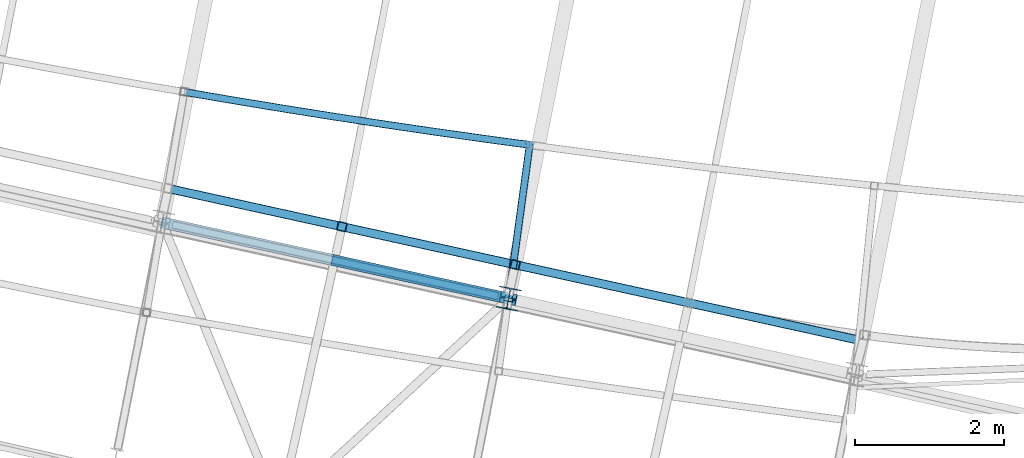
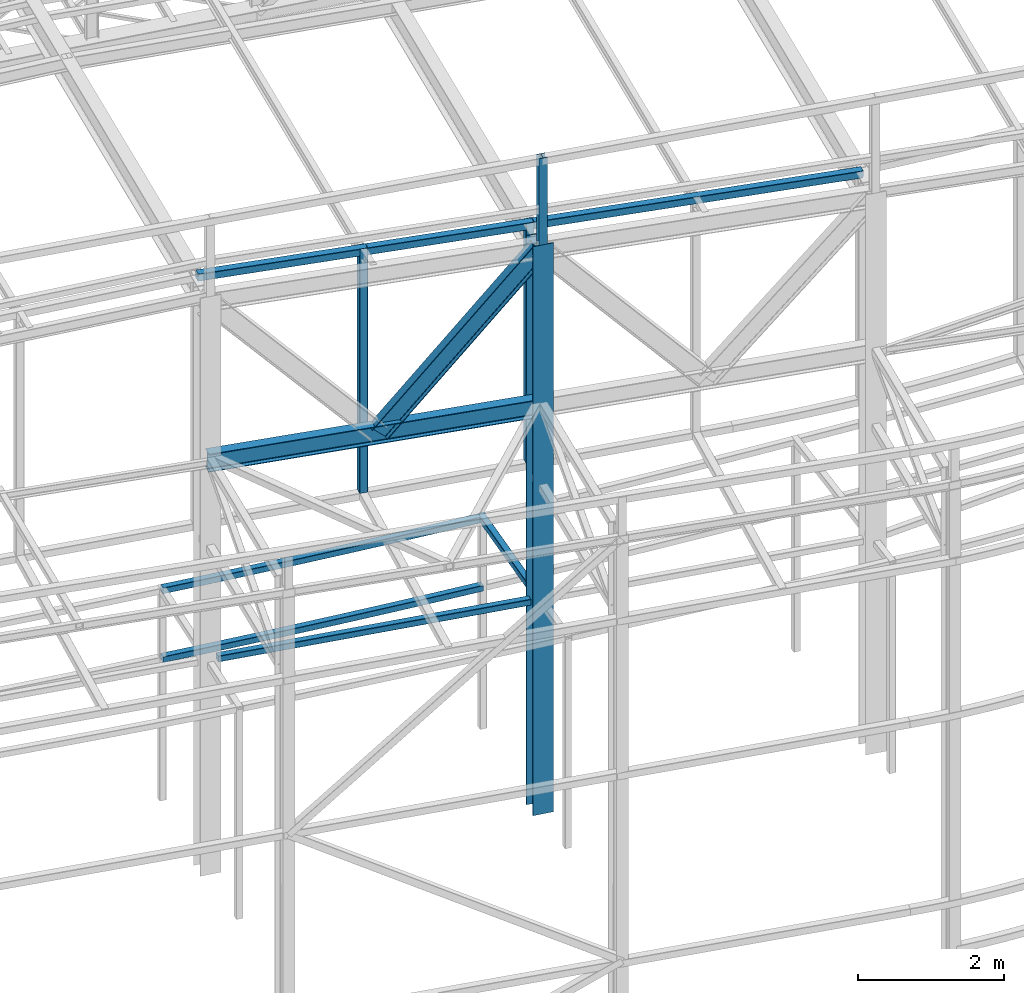
# One storey, part 48 of 215: 10 beams, 1 member, 11 elements without a shape of their own.
"""IFC2X3 building model written with IfcOpenShell, lengths in millimetres."""

from ifc_helpers import new_model, entity, si_unit, frame, origin_with_axes, origin_2d_with_axis, place, context, subcontext, project, spatial, hollow_rectangle, i_section, extrude, clip, halfspace, material, type_object, element, aggregate, save


model = new_model("IFC2X3")

# Units and contexts
model_context = context("Model", 3, precision=1e-05, world=origin_with_axes())
body_context = subcontext(model_context, "Body", "Model", "MODEL_VIEW")
ifc_project = project(units=[si_unit("LENGTHUNIT", "METRE", prefix="MILLI"), si_unit("AREAUNIT", "SQUARE_METRE"), si_unit("VOLUMEUNIT", "CUBIC_METRE"), si_unit("MASSUNIT", "GRAM", prefix="KILO"), si_unit("TIMEUNIT", "SECOND"), si_unit("PLANEANGLEUNIT", "RADIAN"), si_unit("SOLIDANGLEUNIT", "STERADIAN"), si_unit("THERMODYNAMICTEMPERATUREUNIT", "DEGREE_CELSIUS"), si_unit("LUMINOUSINTENSITYUNIT", "LUMEN")], contexts=[model_context])

# Site, building, storey
site_placement = place(None, origin_with_axes())
site = spatial("IfcSite", under=ifc_project, at=site_placement, CompositionType="ELEMENT")
building_placement = place(site_placement, origin_with_axes())
building = spatial("IfcBuilding", under=site, at=building_placement, Name="Undefined", CompositionType="ELEMENT")
storey_placement = place(building_placement, origin_with_axes())
storey = spatial("IfcBuildingStorey", under=building, at=storey_placement, Name="Undefined", CompositionType="ELEMENT", Elevation=0.0)

# Assembly, beam
assembly_1_placement = place(storey_placement, origin_with_axes())
assembly_1 = element("IfcElementAssembly", 1, at=assembly_1_placement, inside=storey, Name="Steel Assembly", AssemblyPlace="NOTDEFINED", PredefinedType="RIGID_FRAME")
ifc_material = material(Name="STEEL/S275JR")
beam_type_1 = type_object("IfcBeamType", PredefinedType="NOTDEFINED")
beam_1_placement = place(assembly_1_placement, frame((65224.8840852946, 7582.713268149, 5610.00000147687), z_axis=(0.151591500013024, 0.988443229084909, 0.0), x_axis=(0.988443229084909, -0.151591500013022, 0.0)))
beam_1 = element("IfcBeam", 2, at=beam_1_placement, type_object=beam_type_1, material=ifc_material, Name="POUTRE", context=body_context, shape_type="SweptSolid", body=[
    entity("IfcRevolvedAreaSolid", entity("IfcRectangleHollowProfileDef", "AREA", None, entity("IfcAxis2Placement2D", entity("IfcCartesianPoint", [0.0, 0.0]), entity("IfcDirection", [1.0, 0.0])), 100.0, 100.0, 4.0, 4.0, 8.0), entity("IfcAxis2Placement3D", entity("IfcCartesianPoint", [4706.94890203642, 0.0, 0.0]), entity("IfcDirection", [-0.999807660600292, 0.0, -0.0196122870918184]), entity("IfcDirection", [-6.93889390390723e-18, -1.0, -3.46944695195361e-18])), entity("IfcAxis1Placement", entity("IfcCartesianPoint", [0.0, 120000.0, 0.0]), entity("IfcDirection", [-1.0, 0.0, 0.0])), 0.0392270891874841),
])
aggregate(assembly_1, [beam_1])

assembly_2_placement = place(storey_placement, origin_with_axes())
assembly_2 = element("IfcElementAssembly", 3, at=assembly_2_placement, inside=storey, Name="Steel Assembly", AssemblyPlace="NOTDEFINED", PredefinedType="RIGID_FRAME")
beam_2_placement = place(assembly_2_placement, frame((64927.386819947, 5826.10594443093, 6760.00000147687), z_axis=(0.214798002056691, 0.976658496257752, 0.0), x_axis=(0.976658496257753, -0.214798002056688, 0.0)))
beam_2 = element("IfcBeam", 4, at=beam_2_placement, type_object=beam_type_1, material=ifc_material, Name="POUTRE", context=body_context, shape_type="Clipping", body=[
    clip(clip(extrude(hollow_rectangle(XDim=100.0, YDim=100.0, WallThickness=4.0, InnerFilletRadius=4.0, OuterFilletRadius=8.0, at=origin_2d_with_axis()), frame((4673.31195125505, 0.0, 0.0), z_axis=(-1.0, 0.0, 0.0), x_axis=(-6.93889390390723e-18, -1.0, -3.46944695195361e-18)), (0.0, 0.0, 1.0), 4568.5), halfspace(frame((4635.60318619382, -50.0, -107.513461073951), z_axis=(0.999725564992657, 0.0, 0.0234263676252406), x_axis=(-6.93889390390723e-18, -1.0, -3.46944695195361e-18)), False)), halfspace(frame((147.371838891799, -50.0, -100.608993199901), z_axis=(0.999725564992657, 0.0, 0.0234263676252406), x_axis=(-6.93889390390723e-18, -1.0, -3.46944695195361e-18)), True)),
])
aggregate(assembly_2, [beam_2])

assembly_3_placement = place(storey_placement, origin_with_axes())
assembly_3 = element("IfcElementAssembly", 5, at=assembly_3_placement, inside=storey, Name="Steel Assembly", AssemblyPlace="NOTDEFINED", PredefinedType="RIGID_FRAME")
beam_3_placement = place(assembly_3_placement, frame((65224.8840850918, 7582.71326812223, 6760.00000147687), z_axis=(0.151591500013024, 0.988443229084909, 0.0), x_axis=(0.988443229084909, -0.151591500013022, 0.0)))
beam_3 = element("IfcBeam", 6, at=beam_3_placement, type_object=beam_type_1, material=ifc_material, Name="POUTRE", context=body_context, shape_type="SweptSolid", body=[
    entity("IfcRevolvedAreaSolid", entity("IfcRectangleHollowProfileDef", "AREA", None, entity("IfcAxis2Placement2D", entity("IfcCartesianPoint", [0.0, 0.0]), entity("IfcDirection", [1.0, 0.0])), 100.0, 100.0, 4.0, 4.0, 8.0), entity("IfcAxis2Placement3D", entity("IfcCartesianPoint", [4706.94890203642, 0.0, 0.0]), entity("IfcDirection", [-0.999807660600292, 0.0, -0.0196122870918184]), entity("IfcDirection", [-6.93889390390723e-18, -1.0, -3.46944695195361e-18])), entity("IfcAxis1Placement", entity("IfcCartesianPoint", [0.0, 120000.0, 0.0]), entity("IfcDirection", [-1.0, 0.0, 0.0])), 0.0392270891869406),
])
aggregate(assembly_3, [beam_3])

assembly_4_placement = place(storey_placement, origin_with_axes())
assembly_4 = element("IfcElementAssembly", 7, at=assembly_4_placement, inside=storey, Name="Steel Assembly", AssemblyPlace="NOTDEFINED", PredefinedType="RIGID_FRAME")
beam_4_placement = place(assembly_4_placement, frame((69621.1231774245, 4997.92434422544, 6760.00000147687), z_axis=(-0.990749114285665, 0.135706273039128, 0.0), x_axis=(0.135706504934543, 0.990749082522134, 0.0)))
beam_4 = element("IfcBeam", 8, at=beam_4_placement, type_object=beam_type_1, material=ifc_material, Name="POUTRE", context=body_context, shape_type="Clipping", body=[
    clip(extrude(hollow_rectangle(XDim=100.0, YDim=100.0, WallThickness=4.0, InnerFilletRadius=4.0, OuterFilletRadius=8.0, at=origin_2d_with_axis()), frame((1938.72794651128, 9.09494701772928e-13, 0.0), z_axis=(-1.0, 0.0, 0.0), x_axis=(-6.93889390390723e-18, -1.0, -3.46944695195361e-18)), (0.0, 0.0, 1.0), 2164.4), halfspace(frame((-192.676442356467, -49.9999999999991, 53.8089574771438), z_axis=(-0.998379927499636, 0.0, 0.0568992123479868), x_axis=(-6.93889390390723e-18, -1.0, -3.46944695195361e-18)), False)),
])
aggregate(assembly_4, [beam_4])

assembly_5_placement = place(storey_placement, origin_with_axes())
assembly_5 = element("IfcElementAssembly", 9, at=assembly_5_placement, inside=storey, Name="Steel Assembly", AssemblyPlace="NOTDEFINED", PredefinedType="RIGID_FRAME")
beam_type_2 = type_object("IfcBeamType", PredefinedType="NOTDEFINED")
beam_5_placement = place(assembly_5_placement, frame((69682.8434912894, 5256.33755628994, 12772.1194348318), z_axis=(-0.214538758981639, -0.97671547591641, 0.0), x_axis=(0.0, 0.0, -1.0)))
beam_5 = element("IfcBeam", 10, at=beam_5_placement, type_object=beam_type_2, material=ifc_material, Name="LISSE", context=body_context, shape_type="SweptSolid", body=[
    extrude(hollow_rectangle(XDim=120.0, YDim=120.0, WallThickness=5.0, InnerFilletRadius=5.0, OuterFilletRadius=10.0, at=origin_2d_with_axis()), frame((4006.11862660427, 0.0, -6.31690010094974e-21), z_axis=(-1.0, 0.0, 0.0), x_axis=(-6.93889390390723e-18, -1.0, -3.46944695195361e-18)), (0.0, 0.0, 1.0), 4006.1),
])
aggregate(assembly_5, [beam_5])

assembly_6_placement = place(storey_placement, origin_with_axes())
assembly_6 = element("IfcElementAssembly", 11, at=assembly_6_placement, inside=storey, Name="Steel Assembly", AssemblyPlace="NOTDEFINED", PredefinedType="RIGID_FRAME")
beam_6_placement = place(assembly_6_placement, frame((67349.7659543305, 5768.80644051236, 12845.7703227553), z_axis=(-0.214538758981639, -0.97671547591641, 0.0), x_axis=(0.0, 0.0, -1.0)))
beam_6 = element("IfcBeam", 12, at=beam_6_placement, type_object=beam_type_2, material=ifc_material, Name="LISSE", context=body_context, shape_type="SweptSolid", body=[
    extrude(hollow_rectangle(XDim=120.0, YDim=120.0, WallThickness=5.0, InnerFilletRadius=5.0, OuterFilletRadius=10.0, at=origin_2d_with_axis()), frame((4079.769514377, -1.34988249839102e-20, 3.63797880740809e-12), z_axis=(-1.0, 0.0, 0.0), x_axis=(-6.93889390390723e-18, -1.0, -3.46944695195361e-18)), (0.0, 0.0, 1.0), 4079.8),
])
aggregate(assembly_6, [beam_6])

assembly_7_placement = place(storey_placement, origin_with_axes())
assembly_7 = element("IfcElementAssembly", 13, at=assembly_7_placement, inside=storey, Name="Steel Assembly", AssemblyPlace="NOTDEFINED", PredefinedType="RIGID_FRAME")
beam_7_placement = place(assembly_7_placement, frame((74356.7337771927, 4229.70072271222, 12563.5995386171), z_axis=(-0.030293452010804, 0.00665406600237362, -0.999518899356538), x_axis=(-0.976245511871228, 0.214435842971715, 0.0310156379959088)))
beam_7 = element("IfcBeam", 14, at=beam_7_placement, type_object=beam_type_2, material=ifc_material, Name="LISSE", context=body_context, shape_type="SweptSolid", body=[
    extrude(hollow_rectangle(XDim=120.0, YDim=120.0, WallThickness=5.0, InnerFilletRadius=5.0, OuterFilletRadius=10.0, at=origin_2d_with_axis()), frame((9557.22869770565, 1.83354023433705e-13, -3.31582979743785e-14), z_axis=(-1.0, 0.0, 0.0), x_axis=(-6.93889390390723e-18, -1.0, -3.46944695195361e-18)), (0.0, 0.0, 1.0), 9557.2),
])
aggregate(assembly_7, [beam_7])

assembly_8_placement = place(storey_placement, origin_with_axes())
assembly_8 = element("IfcElementAssembly", 15, at=assembly_8_placement, inside=storey, Name="Steel Assembly", AssemblyPlace="NOTDEFINED", PredefinedType="RIGID_FRAME")
beam_type_3 = type_object("IfcBeamType", Name="HEA120", PredefinedType="NOTDEFINED")
beam_8_placement = place(assembly_8_placement, frame((69577.0982454659, 4713.40936091959, 14219.9969942534), z_axis=(0.191859470081235, 0.981422408415534, 0.0), x_axis=(0.0, 0.0, -1.0)))
beam_8 = element("IfcBeam", 16, at=beam_8_placement, type_object=beam_type_3, material=ifc_material, ObjectType="HEA120", context=body_context, shape_type="SweptSolid", body=[
    extrude(i_section(OverallWidth=120.0, OverallDepth=114.0, WebThickness=5.0, FlangeThickness=8.0, FilletRadius=12.0, at=origin_2d_with_axis()), frame((1450.35654552193, 0.0, 0.0), z_axis=(-1.0, 0.0, 0.0), x_axis=(-6.93889390390723e-18, -1.0, -3.46944695195361e-18)), (0.0, 0.0, 1.0), 1450.4),
])
aggregate(assembly_8, [beam_8])

assembly_9_placement = place(storey_placement, origin_with_axes())
assembly_9 = element("IfcElementAssembly", 17, at=assembly_9_placement, inside=storey, Name="Steel Assembly", AssemblyPlace="NOTDEFINED", PredefinedType="RIGID_FRAME")
beam_type_4 = type_object("IfcBeamType", Name="IPE300", PredefinedType="NOTDEFINED")
beam_9_placement = place(assembly_9_placement, frame((69593.3001945072, 4799.97825132007, 9991.87561712708), z_axis=(-0.0182014179915463, 0.00402804099812943, -0.999826226535799), x_axis=(-0.976511688088563, 0.214656486019468, 0.0186417820016908)))
beam_9 = element("IfcBeam", 18, at=beam_9_placement, type_object=beam_type_4, material=ifc_material, ObjectType="IPE300", context=body_context, shape_type="SweptSolid", body=[
    extrude(i_section(OverallWidth=150.0, OverallDepth=300.0, WebThickness=7.099999905, FlangeThickness=10.69999981, FilletRadius=15.0, at=origin_2d_with_axis()), frame((4779.11769248609, -3.621180834019e-12, 1.65808953112234e-14), z_axis=(-1.0, 0.0, 0.0), x_axis=(-6.93889390390723e-18, -1.0, -3.46944695195361e-18)), (0.0, 0.0, 1.0), 4779.1),
])
aggregate(assembly_9, [beam_9])

assembly_10_placement = place(storey_placement, origin_with_axes())
assembly_10 = element("IfcElementAssembly", 19, at=assembly_10_placement, inside=storey, Name="Steel Assembly", AssemblyPlace="NOTDEFINED", PredefinedType="RIGID_FRAME")
beam_type_5 = type_object("IfcBeamType", Name="HEA300", PredefinedType="NOTDEFINED")
beam_10_placement = place(assembly_10_placement, frame((69593.9818778255, 4799.77453311764, 12769.6404486195), z_axis=(0.191859470081235, 0.981422408415534, 0.0), x_axis=(0.0, 0.0, -1.0)))
beam_10 = element("IfcBeam", 20, at=beam_10_placement, type_object=beam_type_5, material=ifc_material, Name="POTEAU", ObjectType="HEA300", context=body_context, shape_type="SweptSolid", body=[
    extrude(i_section(OverallWidth=300.0, OverallDepth=290.0, WebThickness=8.5, FlangeThickness=14.0, FilletRadius=27.0, at=origin_2d_with_axis()), frame((9509.64253872002, 0.0, 0.0), z_axis=(-1.0, 0.0, 0.0), x_axis=(-6.93889390390723e-18, -1.0, -3.46944695195361e-18)), (0.0, 0.0, 1.0), 9509.6),
])
aggregate(assembly_10, [beam_10])

# Assembly, member
assembly_11_placement = place(storey_placement, origin_with_axes())
assembly_11 = element("IfcElementAssembly", 21, at=assembly_11_placement, inside=storey, Name="Steel Assembly", AssemblyPlace="NOTDEFINED", PredefinedType="RIGID_FRAME")
member_type = type_object("IfcMemberType", Name="IPE300", PredefinedType="NOTDEFINED")
member_placement = place(assembly_11_placement, frame((67324.7624515248, 5298.59535411145, 10036.0840178212), z_axis=(0.727465646876986, -0.159911821972958, -0.667249534887165), x_axis=(0.651690110956587, -0.143254810990457, 0.744834248950382)))
member = element("IfcMember", 22, at=member_placement, type_object=member_type, material=ifc_material, Name="POUTRE", ObjectType="IPE300", context=body_context, shape_type="SweptSolid", body=[
    extrude(i_section(OverallWidth=150.0, OverallDepth=300.0, WebThickness=7.099999905, FlangeThickness=10.69999981, FilletRadius=15.0, at=origin_2d_with_axis()), frame((3475.03692133817, -3.53609923419559e-12, 1.92903300074607e-13), z_axis=(-1.0, 0.0, 0.0), x_axis=(-6.93889390390723e-18, -1.0, -3.46944695195361e-18)), (0.0, 0.0, 1.0), 3475.0),
])
aggregate(assembly_11, [member])

save(model, "model.ifc")
